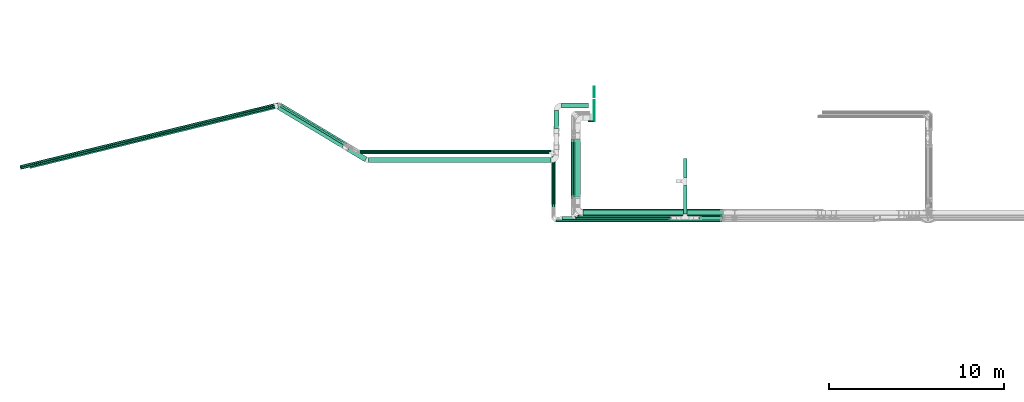
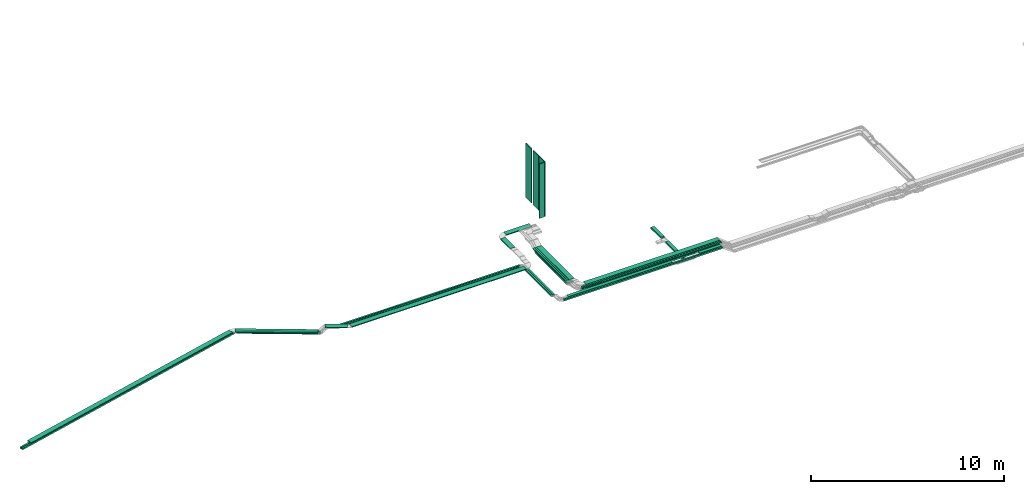
# One storey, part 1 of 28: 31 flow segments.
"""IFC2X3 building model written with IfcOpenShell, lengths in millimetres."""

from ifc_helpers import new_model, entity, si_unit, converted_unit, derived_unit, direction, frame, frame_2d, origin, origin_2d_with_axis, place, context, subcontext, project, spatial, rectangle, extrude, type_object, element, save


model = new_model("IFC2X3")

# Units and contexts
model_context = context("Model", 3, precision=0.01, world=origin(), true_north=direction((6.12303176911189e-17, 1.0)))
body_context = subcontext(model_context, "Body", "Model", "MODEL_VIEW")
ifc_project = project(units=[si_unit("LENGTHUNIT", "METRE", prefix="MILLI"), si_unit("AREAUNIT", "SQUARE_METRE"), si_unit("VOLUMEUNIT", "CUBIC_METRE"), converted_unit("PLANEANGLEUNIT", "DEGREE", entity("IfcRatioMeasure", 0.0174532925199433), si_unit("PLANEANGLEUNIT", "RADIAN"), dimensions=[0, 0, 0, 0, 0, 0, 0]), si_unit("MASSUNIT", "GRAM", prefix="KILO"), derived_unit("MASSDENSITYUNIT", [(si_unit("MASSUNIT", "GRAM", prefix="KILO"), 1), (si_unit("LENGTHUNIT", "METRE"), -3)]), derived_unit("MOMENTOFINERTIAUNIT", [(si_unit("LENGTHUNIT", "METRE"), 4)]), si_unit("TIMEUNIT", "SECOND"), si_unit("FREQUENCYUNIT", "HERTZ"), si_unit("THERMODYNAMICTEMPERATUREUNIT", "DEGREE_CELSIUS"), derived_unit("THERMALTRANSMITTANCEUNIT", [(si_unit("MASSUNIT", "GRAM", prefix="KILO"), 1), (si_unit("THERMODYNAMICTEMPERATUREUNIT", "KELVIN"), -1), (si_unit("TIMEUNIT", "SECOND"), -3)]), derived_unit("VOLUMETRICFLOWRATEUNIT", [(si_unit("LENGTHUNIT", "METRE"), 3), (si_unit("TIMEUNIT", "SECOND"), -1)]), derived_unit("MASSFLOWRATEUNIT", [(si_unit("MASSUNIT", "GRAM", prefix="KILO"), 1), (si_unit("TIMEUNIT", "SECOND"), -1)]), derived_unit("ROTATIONALFREQUENCYUNIT", [(si_unit("TIMEUNIT", "SECOND"), -1)]), si_unit("ELECTRICCURRENTUNIT", "AMPERE"), si_unit("ELECTRICVOLTAGEUNIT", "VOLT"), si_unit("POWERUNIT", "WATT"), si_unit("FORCEUNIT", "NEWTON", prefix="KILO"), si_unit("ILLUMINANCEUNIT", "LUX"), si_unit("LUMINOUSFLUXUNIT", "LUMEN"), si_unit("LUMINOUSINTENSITYUNIT", "CANDELA"), derived_unit("USERDEFINED", [(si_unit("MASSUNIT", "GRAM", prefix="KILO"), -1), (si_unit("LENGTHUNIT", "METRE"), -2), (si_unit("TIMEUNIT", "SECOND"), 3), (si_unit("LUMINOUSFLUXUNIT", "LUMEN"), 1)]), derived_unit("LINEARVELOCITYUNIT", [(si_unit("LENGTHUNIT", "METRE"), 1), (si_unit("TIMEUNIT", "SECOND"), -1)]), si_unit("PRESSUREUNIT", "PASCAL"), derived_unit("USERDEFINED", [(si_unit("LENGTHUNIT", "METRE"), -2), (si_unit("MASSUNIT", "GRAM", prefix="KILO"), 1), (si_unit("TIMEUNIT", "SECOND"), -2)]), derived_unit("LINEARFORCEUNIT", [(si_unit("MASSUNIT", "GRAM", prefix="KILO"), 1), (si_unit("LENGTHUNIT", "METRE"), 1), (si_unit("TIMEUNIT", "SECOND"), -2), (si_unit("LENGTHUNIT", "METRE"), -1)]), derived_unit("PLANARFORCEUNIT", [(si_unit("MASSUNIT", "GRAM", prefix="KILO"), 1), (si_unit("LENGTHUNIT", "METRE"), 1), (si_unit("TIMEUNIT", "SECOND"), -2), (si_unit("LENGTHUNIT", "METRE"), -2)])], contexts=[model_context])

# Site, building, storey
site_placement = place(None, frame((0.0, -0.00077364408347762, 0.0)))
site = spatial("IfcSite", under=ifc_project, at=site_placement, CompositionType="ELEMENT")
building_placement = place(site_placement, origin())
building = spatial("IfcBuilding", under=site, at=building_placement, CompositionType="ELEMENT")
storey_placement = place(building_placement, origin())
storey = spatial("IfcBuildingStorey", under=building, at=storey_placement, CompositionType="ELEMENT", Elevation=0.0)

# Flow segments
cable_carrier_segment_type_1 = type_object("IfcCableCarrierSegmentType", PredefinedType="CABLETRAYSEGMENT")
flow_segment_1_placement = place(storey_placement, frame((15850.9969238281, 8570.00006103522, 3100.0)))
element("IfcFlowSegment", 1, at=flow_segment_1_placement, inside=storey, type_object=cable_carrier_segment_type_1, context=body_context, shape_type="SweptSolid", body=[
    extrude(rectangle(XDim=7974.65921899979, YDim=400.0, at=frame_2d((-2.27373675443232e-12, -5.54223333892878e-13), x_axis=(1.0, 0.0))), frame((3987.3296094999, 200.0, 0.0)), (0.0, 0.0, 1.0), 100.0),
])
flow_segment_2_placement = place(storey_placement, frame((21593.5985265898, 10793.3644987587, 2950.0)))
element("IfcFlowSegment", 2, at=flow_segment_2_placement, inside=storey, type_object=cable_carrier_segment_type_1, context=body_context, shape_type="SweptSolid", body=[
    extrude(rectangle(XDim=1071.71608612061, YDim=199.999999999998, at=origin_2d_with_axis()), frame((100.0, 535.858043060306, 0.0), z_axis=(0.0, 0.0, 1.0), x_axis=(0.0, -1.0, 0.0)), (0.0, 0.0, 1.0), 99.9999999999995),
])
flow_segment_3_placement = place(storey_placement, frame((14644.724290081, 8360.00006103512, 3100.0)))
element("IfcFlowSegment", 3, at=flow_segment_3_placement, inside=storey, type_object=cable_carrier_segment_type_1, context=body_context, shape_type="SweptSolid", body=[
    extrude(rectangle(XDim=6224.94739294661, YDim=200.0, at=frame_2d((0.0, 5.47117906535277e-13), x_axis=(1.0, 0.0))), frame((3112.4736964733, 100.0, 0.0)), (0.0, 0.0, 1.0), 100.0),
])
flow_segment_4_placement = place(storey_placement, frame((14163.724290081, 9105.61750876675, 2950.0)))
element("IfcFlowSegment", 4, at=flow_segment_4_placement, inside=storey, type_object=cable_carrier_segment_type_1, context=body_context, shape_type="SweptSolid", body=[
    extrude(rectangle(XDim=2998.38255226861, YDim=99.9999999999989, at=frame_2d((1.13686837721616e-12, 1.08357767203415e-12), x_axis=(1.0, 0.0))), frame((50.0, 1499.1912761343, 0.0), z_axis=(0.0, 0.0, 1.0), x_axis=(0.0, -1.0, 0.0)), (0.0, 0.0, 1.0), 100.0),
])
flow_segment_5_placement = place(storey_placement, frame((3071.29487724489, 12255.0000610354, 2950.0)))
element("IfcFlowSegment", 5, at=flow_segment_5_placement, inside=storey, type_object=cable_carrier_segment_type_1, context=body_context, shape_type="SweptSolid", body=[
    extrude(rectangle(XDim=10941.4294128361, YDim=99.9999999999989, at=origin_2d_with_axis()), frame((5470.71470641806, 50.0, 0.0), z_axis=(0.0, 0.0, 1.0), x_axis=(-1.0, 0.0, 0.0)), (0.0, 0.0, 1.0), 100.0),
])
flow_segment_6_placement = place(storey_placement, frame((-1476.17370525667, 12676.6090704851, 2600.0)))
element("IfcFlowSegment", 6, at=flow_segment_6_placement, inside=storey, type_object=cable_carrier_segment_type_1, context=body_context, shape_type="SweptSolid", body=[
    extrude(rectangle(XDim=4404.58031867628, YDim=99.9999999999999, at=frame_2d((-6.82121026329696e-13, 8.81072992342524e-13), x_axis=(1.0, 0.0))), frame((1913.4830149882, 1177.12164909398, 0.0), z_axis=(0.0, 0.0, 1.0), x_axis=(0.857167300702113, -0.515038074910054, 0.0)), (0.0, 0.0, 1.0), 100.0),
])
flow_segment_7_placement = place(storey_placement, frame((-16390.6842074169, 11360.7978991802, 2600.0)))
element("IfcFlowSegment", 7, at=flow_segment_7_placement, inside=storey, type_object=cable_carrier_segment_type_1, context=body_context, shape_type="SweptSolid", body=[
    extrude(rectangle(XDim=15208.8618462409, YDim=99.9999999999989, at=origin_2d_with_axis()), frame((7399.95147987995, 1849.46460130121, 0.0), z_axis=(0.0, 0.0, 1.0), x_axis=(-0.97155336378743, -0.236820736662416, 0.0)), (0.0, 0.0, 1.0), 100.0),
])
flow_segment_8_placement = place(storey_placement, frame((14304.724290081, 8250.00006103529, 3100.0)))
element("IfcFlowSegment", 8, at=flow_segment_8_placement, inside=storey, type_object=cable_carrier_segment_type_1, context=body_context, shape_type="SweptSolid", body=[
    extrude(rectangle(XDim=9520.9318527469, YDim=99.9999999999989, at=frame_2d((0.0, -5.40012479177676e-13), x_axis=(1.0, 0.0))), frame((4760.46592637345, 50.0, 0.0)), (0.0, 0.0, 1.0), 100.0),
])
flow_segment_9_placement = place(storey_placement, frame((14053.724290081, 9105.61750876686, 2950.0)))
element("IfcFlowSegment", 9, at=flow_segment_9_placement, inside=storey, type_object=cable_carrier_segment_type_1, context=body_context, shape_type="SweptSolid", body=[
    extrude(rectangle(XDim=2878.38255226848, YDim=99.9999999999989, at=frame_2d((-5.6843418860808e-13, 0.0), x_axis=(1.0, 0.0))), frame((50.0, 1439.19127613424, 0.0), z_axis=(0.0, 0.0, 1.0), x_axis=(0.0, -1.0, 0.0)), (0.0, 0.0, 1.0), 100.0),
])
flow_segment_10_placement = place(storey_placement, frame((3057.43197222179, 12135.0000610353, 2950.0)))
element("IfcFlowSegment", 10, at=flow_segment_10_placement, inside=storey, type_object=cable_carrier_segment_type_1, context=body_context, shape_type="SweptSolid", body=[
    extrude(rectangle(XDim=10845.2923178592, YDim=99.9999999999989, at=origin_2d_with_axis()), frame((5422.64615892962, 50.0, 0.0), z_axis=(0.0, 0.0, 1.0), x_axis=(-1.0, 0.0, 0.0)), (0.0, 0.0, 1.0), 100.0),
])
flow_segment_11_placement = place(storey_placement, frame((-1494.06223176433, 12582.3206674071, 2600.0)))
element("IfcFlowSegment", 11, at=flow_segment_11_placement, inside=storey, type_object=cable_carrier_segment_type_1, context=body_context, shape_type="SweptSolid", body=[
    extrude(rectangle(XDim=4359.35500303556, YDim=100.0, at=frame_2d((-4.54747350886464e-13, 8.81072992342524e-13), x_axis=(1.0, 0.0))), frame((1894.10018412262, 1165.47526934159, 0.0), z_axis=(0.0, 0.0, 1.0), x_axis=(0.857167300702109, -0.51503807491006, 0.0)), (0.0, 0.0, 1.0), 100.0),
])
flow_segment_12_placement = place(storey_placement, frame((-16364.633926384, 11253.9270291636, 2600.0)))
element("IfcFlowSegment", 12, at=flow_segment_12_placement, inside=storey, type_object=cable_carrier_segment_type_1, context=body_context, shape_type="SweptSolid", body=[
    extrude(rectangle(XDim=15163.6365305987, YDim=99.9999999999992, at=frame_2d((4.54747350886464e-13, -2.70006239588838e-13), x_axis=(1.0, 0.0))), frame((7377.98207610968, 1844.10945501813, 0.0), z_axis=(0.0, 0.0, 1.0), x_axis=(-0.97155336378743, -0.236820736662417, 0.0)), (0.0, 0.0, 1.0), 99.9999999999999),
])
flow_segment_13_placement = place(storey_placement, frame((15289.9969238281, 9581.07643203831, 3230.0)))
element("IfcFlowSegment", 13, at=flow_segment_13_placement, inside=storey, type_object=cable_carrier_segment_type_1, context=body_context, shape_type="SweptSolid", body=[
    extrude(rectangle(XDim=3404.78726853567, YDim=99.9999999999989, at=frame_2d((-5.6843418860808e-13, -1.08357767203415e-12), x_axis=(1.0, 0.0))), frame((50.0, 1702.39363426783, 0.0), z_axis=(0.0, 0.0, 1.0), x_axis=(0.0, 1.0, 0.0)), (0.0, 0.0, 1.0), 50.0000000000005),
])
flow_segment_14_placement = place(storey_placement, frame((15179.9969238281, 9581.07643203826, 3230.0)))
element("IfcFlowSegment", 14, at=flow_segment_14_placement, inside=storey, type_object=cable_carrier_segment_type_1, context=body_context, shape_type="SweptSolid", body=[
    extrude(rectangle(XDim=3404.78726853591, YDim=99.9999999999989, at=frame_2d((5.6843418860808e-13, -2.16715534406831e-12), x_axis=(1.0, 0.0))), frame((50.0, 1702.39363426795, 0.0), z_axis=(0.0, 0.0, 1.0), x_axis=(0.0, 1.0, 0.0)), (0.0, 0.0, 1.0), 50.0000000000005),
])
flow_segment_15_placement = place(storey_placement, frame((22517.5253701534, 8360.00006103512, 3100.0)))
element("IfcFlowSegment", 15, at=flow_segment_15_placement, inside=storey, type_object=cable_carrier_segment_type_1, context=body_context, shape_type="SweptSolid", body=[
    extrude(rectangle(XDim=1308.13077267465, YDim=200.0, at=origin_2d_with_axis()), frame((654.06538633732, 100.0, 0.0)), (0.0, 0.0, 1.0), 100.0),
])
flow_segment_16_placement = place(storey_placement, frame((21593.5985265898, 8690.00006103512, 2950.0)))
element("IfcFlowSegment", 16, at=flow_segment_16_placement, inside=storey, type_object=cable_carrier_segment_type_1, context=body_context, shape_type="SweptSolid", body=[
    extrude(rectangle(XDim=1643.36443772362, YDim=199.999999999998, at=frame_2d((5.11590769747272e-13, 0.0), x_axis=(1.0, 0.0))), frame((100.0, 821.682218861808, 0.0), z_axis=(0.0, 0.0, 1.0), x_axis=(0.0, -1.0, 0.0)), (0.0, 0.0, 1.0), 100.0),
])
flow_segment_17_placement = place(storey_placement, frame((15399.9969238281, 9581.07643203802, 3230.0)))
element("IfcFlowSegment", 17, at=flow_segment_17_placement, inside=storey, type_object=cable_carrier_segment_type_1, context=body_context, shape_type="SweptSolid", body=[
    extrude(rectangle(XDim=3404.78726853175, YDim=300.000000000001, at=frame_2d((-1.13686837721616e-12, 1.08002495835535e-12), x_axis=(1.0, 0.0))), frame((150.0, 1702.39363426588, 1.37307551995036e-09), z_axis=(0.0, 0.0, 1.0), x_axis=(0.0, -1.0, 0.0)), (0.0, 0.0, 1.0), 49.9999999999995),
])
flow_segment_18_placement = place(storey_placement, frame((14630.9969238281, 14757.6093717678, 3200.0)))
element("IfcFlowSegment", 18, at=flow_segment_18_placement, inside=storey, type_object=cable_carrier_segment_type_1, context=body_context, shape_type="SweptSolid", body=[
    extrude(rectangle(XDim=1526.30884229986, YDim=300.000000000001, at=frame_2d((-1.08002495835535e-12, 0.0), x_axis=(1.0, 0.0))), frame((763.154421149929, 150.0, 0.0), z_axis=(0.0, 0.0, 1.0), x_axis=(-1.0, 0.0, 0.0)), (0.0, 0.0, 1.0), 49.9999999999995),
])
flow_segment_19_placement = place(storey_placement, frame((3570.13215639274, 11625.2683846925, 3150.0)))
element("IfcFlowSegment", 19, at=flow_segment_19_placement, inside=storey, type_object=cable_carrier_segment_type_1, context=body_context, shape_type="SweptSolid", body=[
    extrude(rectangle(XDim=10458.8647674354, YDim=300.000000000001, at=origin_2d_with_axis()), frame((5229.43238371772, 150.0, 0.0), z_axis=(0.0, 0.0, 1.0), x_axis=(-1.0, 0.0, 0.0)), (0.0, 0.0, 1.0), 49.9999999999995),
])
flow_segment_20_placement = place(storey_placement, frame((15850.9969238281, 8620.00006103512, 3350.0)))
element("IfcFlowSegment", 20, at=flow_segment_20_placement, inside=storey, type_object=cable_carrier_segment_type_1, context=body_context, shape_type="SweptSolid", body=[
    extrude(rectangle(XDim=8009.29673573433, YDim=299.999999999999, at=origin_2d_with_axis()), frame((4004.64836786717, 150.0, 0.0)), (0.0, 0.0, 1.0), 50.0000000000005),
])
flow_segment_21_placement = place(storey_placement, frame((15540.9969238281, 8510.00006103504, 3350.0)))
element("IfcFlowSegment", 21, at=flow_segment_21_placement, inside=storey, type_object=cable_carrier_segment_type_1, context=body_context, shape_type="SweptSolid", body=[
    extrude(rectangle(XDim=8319.2967357344, YDim=99.9999999999989, at=frame_2d((0.0, -1.08357767203415e-12), x_axis=(1.0, 0.0))), frame((4159.6483678672, 50.0, 0.0)), (0.0, 0.0, 1.0), 50.0000000000005),
])
flow_segment_22_placement = place(storey_placement, frame((15430.9969238281, 8400.00006103516, 3350.0)))
element("IfcFlowSegment", 22, at=flow_segment_22_placement, inside=storey, type_object=cable_carrier_segment_type_1, context=body_context, shape_type="SweptSolid", body=[
    extrude(rectangle(XDim=8429.29673573445, YDim=99.9999999999989, at=frame_2d((1.81898940354586e-12, 0.0), x_axis=(1.0, 0.0))), frame((4214.64836786722, 50.0, 0.0)), (0.0, 0.0, 1.0), 50.0000000000005),
])
flow_segment_23_placement = place(storey_placement, frame((15299.9969238281, 9660.35783506441, 2940.0)))
element("IfcFlowSegment", 23, at=flow_segment_23_placement, inside=storey, type_object=cable_carrier_segment_type_1, context=body_context, shape_type="SweptSolid", body=[
    extrude(rectangle(XDim=3284.22401747535, YDim=400.0, at=frame_2d((1.02318153949454e-12, -1.09423581307055e-12), x_axis=(1.0, 0.0))), frame((200.0, 1642.11200873768, 0.0), z_axis=(0.0, 0.0, 1.0), x_axis=(0.0, -1.0, 0.0)), (0.0, 0.0, 1.0), 100.0),
])
flow_segment_24_placement = place(storey_placement, frame((14179.9969238281, 13577.1236379161, 3200.0)))
element("IfcFlowSegment", 24, at=flow_segment_24_placement, inside=storey, type_object=cable_carrier_segment_type_1, context=body_context, shape_type="SweptSolid", body=[
    extrude(rectangle(XDim=1029.48573385168, YDim=300.000000000001, at=frame_2d((0.0, -2.17426077142591e-12), x_axis=(1.0, 0.0))), frame((150.0, 514.742866925845, 0.0), z_axis=(0.0, 0.0, 1.0), x_axis=(0.0, -1.0, 0.0)), (0.0, 0.0, 1.0), 50.0000000000005),
])
flow_segment_25_placement = place(storey_placement, frame((2333.89901920588, 11690.0581374515, 3150.0)))
element("IfcFlowSegment", 25, at=flow_segment_25_placement, inside=storey, type_object=cable_carrier_segment_type_1, context=body_context, shape_type="SweptSolid", body=[
    extrude(rectangle(XDim=1169.67695262687, YDim=299.999999999999, at=frame_2d((2.27373675443232e-13, 1.4210854715202e-13), x_axis=(1.0, 0.0))), frame((578.560129324829, 429.789178079129, 0.0), z_axis=(0.0, 0.0, 1.0), x_axis=(-0.857167300702099, 0.515038074910076, 0.0)), (0.0, 0.0, 1.0), 49.9999999999995),
])
flow_segment_26_placement = place(storey_placement, frame((-1662.61451503638, 12469.1261715633, 2800.0)))
element("IfcFlowSegment", 26, at=flow_segment_26_placement, inside=storey, type_object=cable_carrier_segment_type_1, context=body_context, shape_type="SweptSolid", body=[
    extrude(rectangle(XDim=4319.50148221799, YDim=300.000000000002, at=frame_2d((4.54747350886464e-13, -9.52127265918534e-13), x_axis=(1.0, 0.0))), frame((1928.52342418228, 1240.92895909167, 0.0), z_axis=(0.0, 0.0, 1.0), x_axis=(-0.857167300702108, 0.515038074910062, 0.0)), (0.0, 0.0, 1.0), 50.0000000000005),
])
flow_segment_27_placement = place(storey_placement, frame((-15874.3068820181, 11292.3566466257, 2800.0)))
element("IfcFlowSegment", 27, at=flow_segment_27_placement, inside=storey, type_object=cable_carrier_segment_type_1, context=body_context, shape_type="SweptSolid", body=[
    extrude(rectangle(XDim=14436.7145710913, YDim=299.999999999999, at=frame_2d((-4.54747350886464e-13, -1.08002495835535e-12), x_axis=(1.0, 0.0))), frame((7048.54241229069, 1855.18969442377, 0.0), z_axis=(0.0, 0.0, 1.0), x_axis=(-0.971553363787423, -0.236820736662447, 0.0)), (0.0, 0.0, 1.0), 49.9999999999994),
])
cable_carrier_segment_type_2 = type_object("IfcCableCarrierSegmentType", PredefinedType="CABLETRAYSEGMENT")
for number, where in (
    (28, (16472.305766128, 15367.6093717678, 4230.84199571755)),
    (29, (16472.305766128, 14607.6093717678, 4230.84199571755)),
):
    element("IfcFlowSegment", number, at=place(storey_placement, frame(where)), inside=storey, type_object=cable_carrier_segment_type_2, context=body_context, shape_type="SweptSolid", body=[
        extrude(rectangle(XDim=50.0000000000016, YDim=600.000000000002, at=origin_2d_with_axis()), frame((25.0, 300.0, 0.0), z_axis=(0.0, 0.0, 1.0), x_axis=(-1.0, 0.0, 0.0)), (0.0, 0.0, 1.0), 3440.0),
    ])
flow_segment_28_placement = place(storey_placement, frame((16472.305766128, 13987.6093717678, 4230.84199571755)))
element("IfcFlowSegment", 30, at=flow_segment_28_placement, inside=storey, type_object=cable_carrier_segment_type_2, context=body_context, shape_type="SweptSolid", body=[
    extrude(rectangle(XDim=50.0000000000016, YDim=599.999999999998, at=frame_2d((0.0, 2.1600499167107e-12), x_axis=(1.0, 0.0))), frame((25.0, 300.0, 0.0), z_axis=(0.0, 0.0, 1.0), x_axis=(-1.0, 0.0, 0.0)), (0.0, 0.0, 1.0), 3440.0),
])
flow_segment_29_placement = place(storey_placement, frame((16147.305766128, 13967.6093717678, 4225.84199571755)))
element("IfcFlowSegment", 31, at=flow_segment_29_placement, inside=storey, type_object=cable_carrier_segment_type_2, context=body_context, shape_type="SweptSolid", body=[
    extrude(rectangle(XDim=50.0000000000016, YDim=300.000000000001, at=origin_2d_with_axis()), frame((150.0, 25.0, 0.0), z_axis=(0.0, 0.0, 1.0), x_axis=(0.0, 1.0, 0.0)), (0.0, 0.0, 1.0), 3445.0),
])

save(model, "model.ifc")
